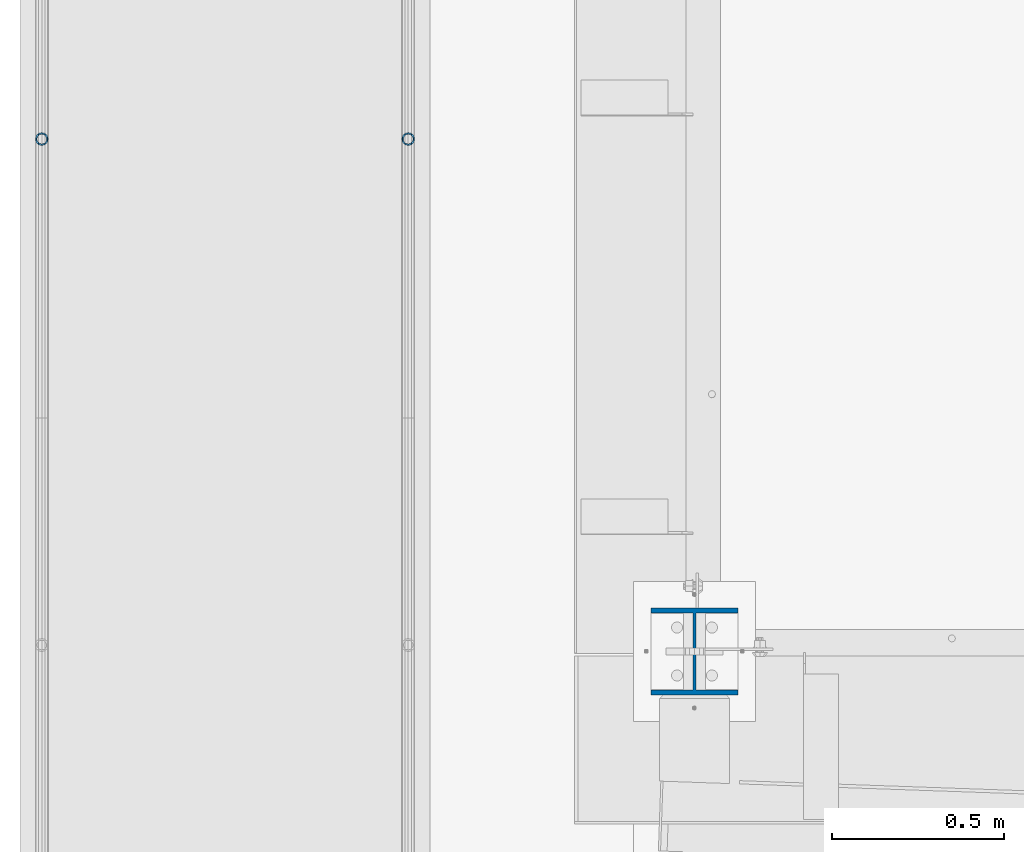
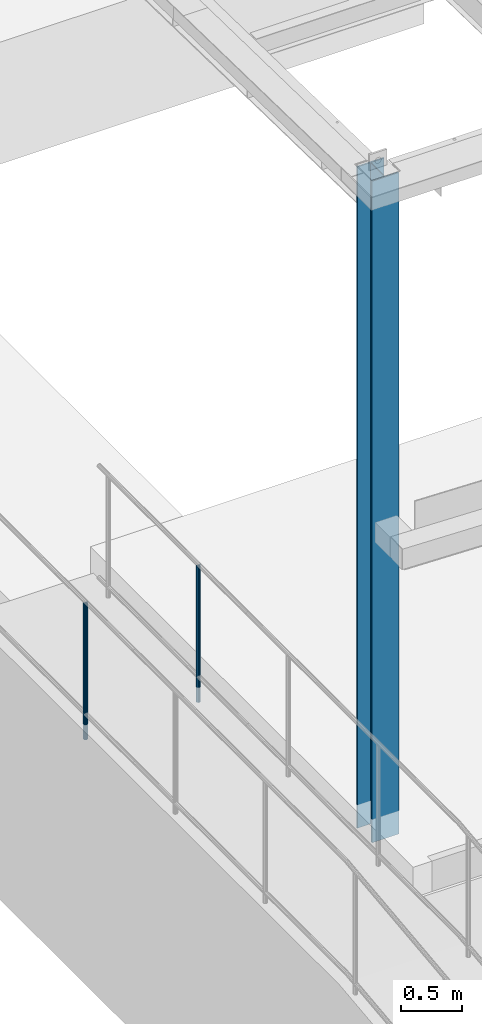
# One storey, part 885 of 1763: 3 columns, 3 elements without a shape of their own.
"""IFC2X3 building model written with IfcOpenShell, lengths in millimetres."""

import ifcopenshell
import ifcopenshell.guid

model = None  # the IFC model being written
_history = None  # IfcOwnerHistory: only IFC2X3 demands one
_inside = {}  # id of a spatial element -> (the spatial element, [elements in it])
_under = {}  # id of a project, library or spatial element -> (it, [spatial elements below it])
_declared = {}  # id of a project -> (the project, [libraries it declares])
_typed = {}  # id of a type object -> (the type object, [elements of that type])
_made_of = {}  # id of a material, layer set ... -> (it, [elements and type objects made of it])


def new_model(schema):
    """Start an empty IFC model of exactly this schema.

    Asked for "IFC4X3", IfcOpenShell would pick the latest addendum, in which some entities
    have other attributes; the version numbers below select the first issue.
    IFC2X3 requires an IfcOwnerHistory on every rooted entity: one is made here for all.
    """
    global model, _history
    if schema == "IFC4X3":
        model = ifcopenshell.file(schema_version=(4, 3, 0, 0))
    else:
        model = ifcopenshell.file(schema=schema)
    _inside.clear()
    _under.clear()
    _declared.clear()
    _typed.clear()
    _made_of.clear()
    _history = None
    if model.schema == "IFC2X3":
        org = make("IfcOrganization", Name="unknown")
        user = make(
            "IfcPersonAndOrganization",
            ThePerson=make("IfcPerson", FamilyName="unknown"),
            TheOrganization=org,
        )
        app = make(
            "IfcApplication",
            ApplicationDeveloper=org,
            Version="unknown",
            ApplicationFullName="unknown",
            ApplicationIdentifier="unknown",
        )
        _history = make(
            "IfcOwnerHistory",
            OwningUser=user,
            OwningApplication=app,
            ChangeAction="ADDED",
            CreationDate=0,
        )
    return model


def make(cls, **values):
    """One entity of the class cls with the attributes given. An attribute that is None is left unset."""
    return model.create_entity(
        cls, **{name: value for name, value in values.items() if value is not None}
    )


def rooted(cls, **values):
    """An entity with a GlobalId (a new one), such as an element, a storey or a relation."""
    return make(cls, GlobalId=ifcopenshell.guid.new(), OwnerHistory=_history, **values)


def si_unit(unit_type, name, prefix=None):
    """IfcSIUnit, for example si_unit("LENGTHUNIT", "METRE", prefix="MILLI")."""
    return make("IfcSIUnit", UnitType=unit_type, Prefix=prefix, Name=name)


def assignment(units):
    """IfcUnitAssignment: the units of a project."""
    return None if units is None else make("IfcUnitAssignment", Units=units)


def point(xyz):
    """IfcCartesianPoint."""
    return None if xyz is None else make("IfcCartesianPoint", Coordinates=xyz)


def direction(xyz):
    """IfcDirection."""
    return None if xyz is None else make("IfcDirection", DirectionRatios=xyz)


def frame(location, z_axis=None, x_axis=None):
    """IfcAxis2Placement3D, a coordinate frame: its origin and axes. An axis left out is left unset."""
    return make(
        "IfcAxis2Placement3D",
        Location=point(location),
        Axis=direction(z_axis),
        RefDirection=direction(x_axis),
    )


def origin_with_axes():
    """The frame at (0, 0, 0) with the z axis (0, 0, 1) and the x axis (1, 0, 0) written out."""
    return frame((0.0, 0.0, 0.0), z_axis=(0.0, 0.0, 1.0), x_axis=(1.0, 0.0, 0.0))


def place(relative_to, where):
    """IfcLocalPlacement: puts the frame where relative to a parent placement (None: the world)."""
    return make(
        "IfcLocalPlacement", PlacementRelTo=relative_to, RelativePlacement=where
    )


def context(
    kind, dimensions, precision=None, world=None, true_north=None, identifier=None
):
    """IfcGeometricRepresentationContext, for example the 3D "Model" context."""
    return make(
        "IfcGeometricRepresentationContext",
        ContextIdentifier=identifier,
        ContextType=kind,
        CoordinateSpaceDimension=dimensions,
        Precision=precision,
        WorldCoordinateSystem=world,
        TrueNorth=true_north,
    )


def subcontext(parent, identifier, kind, view, scale=None):
    """IfcGeometricRepresentationSubContext, for example "Body" below "Model"."""
    return make(
        "IfcGeometricRepresentationSubContext",
        ContextIdentifier=identifier,
        ContextType=kind,
        ParentContext=parent,
        TargetScale=scale,
        TargetView=view,
    )


def project(units=None, contexts=None):
    """IfcProject with its units and contexts."""
    return rooted(
        "IfcProject",
        Name="project",
        RepresentationContexts=contexts,
        UnitsInContext=assignment(units),
    )


def spatial(cls, under=None, at=None, **own):
    """A site, building, storey or space (cls), placed at a placement, below another one or the project."""
    s = rooted(cls, ObjectPlacement=at, **own)
    if under is not None:
        _under.setdefault(under.id(), (under, []))[1].append(s)
    return s


def faces_of(points, faces, orient=None, outer=None):
    """IfcFace entities. A face is a list of loops; a loop is a list of indices into points, from 0.

    orient and outer hold one flag for each loop. By default every Orientation is true, the
    first loop of a face is its IfcFaceOuterBound and the others are IfcFaceBound.
    """
    made = []
    for i, loops in enumerate(faces):
        bounds = []
        for j, loop in enumerate(loops):
            is_outer = j == 0 if outer is None else outer[i][j]
            bounds.append(
                make(
                    "IfcFaceOuterBound" if is_outer else "IfcFaceBound",
                    Bound=make("IfcPolyLoop", Polygon=[points[k] for k in loop]),
                    Orientation=True if orient is None else orient[i][j],
                )
            )
        made.append(make("IfcFace", Bounds=bounds))
    return made


def faceted_brep(points, faces, orient=None, outer=None, voids=None):
    """IfcFacetedBrep: a solid bounded by flat faces; with voids (closed shells), ...WithVoids."""
    shared = [point(p) for p in points]
    hull = make("IfcClosedShell", CfsFaces=faces_of(shared, faces, orient, outer))
    if voids is None:
        return make("IfcFacetedBrep", Outer=hull)
    return make(
        "IfcFacetedBrepWithVoids",
        Outer=hull,
        Voids=[
            make(cls, CfsFaces=faces_of(shared, fs, o, b)) for cls, fs, o, b in voids
        ],
    )


def shape(context_of_items, identifier, shape_type, items):
    """IfcShapeRepresentation: the items that make up one representation, for example the "Body"."""
    return make(
        "IfcShapeRepresentation",
        ContextOfItems=context_of_items,
        RepresentationIdentifier=identifier,
        RepresentationType=shape_type,
        Items=items,
    )


def material(Name=None, Category=None):
    """IfcMaterial."""
    return make("IfcMaterial", Name=Name, Category=Category)


def made_of(thing, what):
    """Note that an element or type object is made of a material, layer set ...; save() writes the relation."""
    if what is not None:
        _made_of.setdefault(what.id(), (what, []))[1].append(thing)
    return thing


def type_object(cls, material=None, **own):
    """A type object (cls), such as IfcWallType, which elements share."""
    return made_of(rooted(cls, **own), material)


def element(
    cls,
    number,
    at=None,
    inside=None,
    cuts=None,
    type_object=None,
    material=None,
    context=None,
    identifier="Body",
    shape_type=None,
    held_by="IfcProductDefinitionShape",
    body=None,
    shapes=None,
    **own,
):
    """One element of the class cls, such as IfcWall. Its Tag is "e" and its number.

    at: its placement. inside: the storey or other place that contains it. cuts: it is an
    opening in that element (IfcRelVoidsElement). A single representation is given by context,
    identifier, shape_type and body (its items); several are given by shapes. held_by: the class
    of the entity that holds the representations. save() writes the other relations.
    """
    e = rooted(cls, Tag="e%d" % number, ObjectPlacement=at, **own)
    if body is not None:
        shapes = [shape(context, identifier, shape_type, body)]
    if shapes is not None:
        e.Representation = make(held_by, Representations=shapes)
    if inside is not None:
        _inside.setdefault(inside.id(), (inside, []))[1].append(e)
    if cuts is not None:
        rooted(
            "IfcRelVoidsElement", RelatingBuildingElement=cuts, RelatedOpeningElement=e
        )
    if type_object is not None:
        _typed.setdefault(type_object.id(), (type_object, []))[1].append(e)
    return made_of(e, material)


def aggregate(whole, parts):
    """IfcRelAggregates: a whole, such as a stair, and the parts it consists of."""
    return rooted("IfcRelAggregates", RelatingObject=whole, RelatedObjects=parts)


def save(model, path):
    """Write the relations noted so far, then the file.

    IfcRelAggregates (storeys below a building ...), IfcRelContainedInSpatialStructure (elements
    in a storey), IfcRelDefinesByType, IfcRelAssociatesMaterial and IfcRelDeclares: one each for
    every whole, place, type object, material and project.
    """
    for whole, parts in _under.values():
        aggregate(whole, parts)
    for where, things in _inside.values():
        rooted(
            "IfcRelContainedInSpatialStructure",
            RelatedElements=things,
            RelatingStructure=where,
        )
    for kind, things in _typed.values():
        rooted("IfcRelDefinesByType", RelatedObjects=things, RelatingType=kind)
    for what, things in _made_of.values():
        rooted("IfcRelAssociatesMaterial", RelatedObjects=things, RelatingMaterial=what)
    for by, libraries in _declared.values():
        rooted("IfcRelDeclares", RelatingContext=by, RelatedDefinitions=libraries)
    model.write(path)


model = new_model("IFC2X3")

# Units and contexts
model_context = context("Model", 3, precision=1e-05, world=origin_with_axes())
body_context = subcontext(model_context, "Body", "Model", "MODEL_VIEW")
ifc_project = project(units=[si_unit("LENGTHUNIT", "METRE", prefix="MILLI"), si_unit("AREAUNIT", "SQUARE_METRE"), si_unit("VOLUMEUNIT", "CUBIC_METRE"), si_unit("MASSUNIT", "GRAM", prefix="KILO"), si_unit("TIMEUNIT", "SECOND"), si_unit("PLANEANGLEUNIT", "RADIAN"), si_unit("SOLIDANGLEUNIT", "STERADIAN"), si_unit("THERMODYNAMICTEMPERATUREUNIT", "DEGREE_CELSIUS"), si_unit("LUMINOUSINTENSITYUNIT", "LUMEN")], contexts=[model_context])

# Site, building, storey
site_placement = place(None, origin_with_axes())
site = spatial("IfcSite", under=ifc_project, at=site_placement, CompositionType="ELEMENT")
building_placement = place(site_placement, origin_with_axes())
building = spatial("IfcBuilding", under=site, at=building_placement, Name="Undefined", CompositionType="ELEMENT")
storey_placement = place(building_placement, origin_with_axes())
storey = spatial("IfcBuildingStorey", under=building, at=storey_placement, Name="Undefined", CompositionType="ELEMENT", Elevation=0.0)

# Assembly, column
assembly_1_placement = place(storey_placement, origin_with_axes())
assembly_1 = element("IfcElementAssembly", 1, at=assembly_1_placement, inside=storey, Name="GUARDRAIL", AssemblyPlace="NOTDEFINED", PredefinedType="RIGID_FRAME")
ifc_material_1 = material(Name="STEEL/A513")
column_type_1 = type_object("IfcColumnType", PredefinedType="NOTDEFINED")
column_1_placement = place(assembly_1_placement, frame((-97200.6527017878, 10788.4431732146, 5777.83146284698), z_axis=(0.0, -1.0, 0.0), x_axis=(0.0, 0.0, 1.0)))
column_1 = element("IfcColumn", 2, at=column_1_placement, type_object=column_type_1, material=ifc_material_1, Name="POST TUBE", context=body_context, shape_type="Brep", body=[
    faceted_brep([(1355.1020678918, -9.52499999999418, 16.4977839408602), (1355.10207152849, -9.52499999999418, 9.99208795533559), (1354.46401618279, -7.14375000000291, 12.3733379553378), (1352.54985306944, 0.0, 14.2874999987689), (1352.5498504072, 0.0, 19.0499999987696), (1354.46401618279, 7.14375000000291, 12.3733379553378), (1355.10207152849, 9.52499999999418, 9.99208795533559), (1355.1020678918, 9.52499999999418, 16.4977839408602), (1371.59986105617, 19.0500000000029, -1.24782673083246e-09), (1362.07485573169, 16.4977839420899, 9.5249999987609), (1362.07486638065, 16.4977839420899, -9.52500000124019), (1357.95041107718, 12.3733379565674, 7.143749998766), (1359.86457711397, 14.2875000000058, -1.23691279441118e-09), (1357.95041906389, 12.3733379565674, -7.14375000123619), (1355.10208269966, 9.52499999999418, -9.99208795780396), (1355.10208633635, 9.52499999999418, -16.4977839433304), (1354.46403001618, 7.14375000000291, -12.3733379578043), (1352.54986904289, 0.0, -14.2875000012336), (1352.54987170513, 0.0, -19.0500000012325), (1355.10208269966, -9.52499999999418, -9.99208795780396), (1355.10208633635, -9.52499999999418, -16.4977839433304), (1354.46403001618, -7.14375000000291, -12.3733379578043), (1371.59986105617, -19.0500000000029, -1.24782673083246e-09), (1362.07486638065, -16.4977839420899, -9.52500000124019), (1362.07485573169, -16.4977839420899, 9.5249999987609), (1357.95041906389, -12.3733379565674, -7.14375000123619), (1359.86457711397, -14.2875000000058, -1.23691279441118e-09), (1357.95041107718, -12.3733379565674, 7.143749998766), (0.0, -16.4977839420899, -9.52500000000146), (0.0, -9.52499999999418, -16.4977839420935), (1.45519152283669e-11, 1.81898940354586e-12, -19.0499999999993), (0.0, 9.52499999999418, -16.4977839420935), (0.0, 16.4977839420899, -9.52500000000146), (0.0, 19.0500000000029, 0.0), (0.0, 16.4977839420899, 9.52500000000146), (0.0, 9.52499999999418, 16.4977839420935), (1.45519152283669e-11, 1.81898940354586e-12, 19.0499999999993), (0.0, -9.52499999999418, 16.4977839420935), (0.0, -16.4977839420899, 9.52500000000146), (0.0, -19.0500000000029, 0.0), (0.0, -12.3733379565674, -7.14374999999927), (0.0, -7.14375000000291, -12.373337956571), (0.0, 0.0, -14.2874999999985), (0.0, 7.14375000000291, -12.373337956571), (0.0, 12.3733379565674, -7.14374999999927), (0.0, 14.2875000000058, 0.0), (0.0, 12.3733379565674, 7.14374999999927), (0.0, 7.14375000000291, 12.373337956571), (0.0, 0.0, 14.2874999999985), (0.0, -7.14375000000291, 12.373337956571), (0.0, -12.3733379565674, 7.14374999999927), (0.0, -14.2875000000058, 0.0)], [[[0, 1, 2, 3, 4]], [[4, 3, 5, 6, 7]], [[8, 9, 10]], [[7, 6, 11, 12, 13, 14, 15, 10, 9]], [[16, 17, 18, 15, 14]], [[19, 20, 18, 17, 21]], [[22, 23, 24]], [[24, 23, 20, 19, 25, 26, 27, 1, 0]], [[28, 29, 20, 23]], [[29, 30, 18, 20]], [[30, 31, 15, 18]], [[31, 32, 10, 15]], [[32, 33, 8, 10]], [[33, 34, 9, 8]], [[34, 35, 7, 9]], [[35, 36, 4, 7]], [[36, 37, 0, 4]], [[37, 38, 24, 0]], [[38, 39, 22, 24]], [[39, 28, 23, 22]], [[38, 37, 36, 35, 34, 33, 32, 31, 30, 29, 28, 39], [40, 41, 42, 43, 44, 45, 46, 47, 48, 49, 50, 51]], [[40, 51, 26, 25]], [[21, 41, 40, 25, 19]], [[42, 41, 21, 17]], [[43, 42, 17, 16]], [[44, 43, 16, 14, 13]], [[45, 44, 13, 12]], [[46, 45, 12, 11]], [[5, 47, 46, 11, 6]], [[48, 47, 5, 3]], [[49, 48, 3, 2]], [[50, 49, 2, 1, 27]], [[51, 50, 27, 26]]]),
])
aggregate(assembly_1, [column_1])

assembly_2_placement = place(storey_placement, origin_with_axes())
assembly_2 = element("IfcElementAssembly", 3, at=assembly_2_placement, inside=storey, Name="GUARDRAIL", AssemblyPlace="NOTDEFINED", PredefinedType="RIGID_FRAME")
column_2_placement = place(assembly_2_placement, frame((-96133.8527017878, 10788.4431732146, 5777.83146284698), z_axis=(0.0, -1.0, 0.0), x_axis=(0.0, 0.0, 1.0)))
column_2 = element("IfcColumn", 4, at=column_2_placement, type_object=column_type_1, material=ifc_material_1, Name="POST TUBE", context=body_context, shape_type="Brep", body=[
    faceted_brep([(1355.1020678918, -9.52499999999418, 16.4977839408602), (1355.10207152849, -9.52499999999418, 9.99208795533559), (1354.46401618279, -7.14375000000291, 12.3733379553378), (1352.54985306944, 0.0, 14.2874999987689), (1352.5498504072, 0.0, 19.0499999987696), (1354.46401618279, 7.14375000000291, 12.3733379553378), (1355.10207152849, 9.52499999999418, 9.99208795533559), (1355.1020678918, 9.52499999999418, 16.4977839408602), (1371.59986105617, 19.0500000000029, -1.24782673083246e-09), (1362.07485573169, 16.4977839420899, 9.5249999987609), (1362.07486638065, 16.4977839420899, -9.52500000124019), (1357.95041107718, 12.3733379565674, 7.143749998766), (1359.86457711397, 14.2875000000058, -1.23691279441118e-09), (1357.95041906389, 12.3733379565674, -7.14375000123619), (1355.10208269966, 9.52499999999418, -9.99208795780396), (1355.10208633635, 9.52499999999418, -16.4977839433304), (1354.46403001618, 7.14375000000291, -12.3733379578043), (1352.54986904289, 0.0, -14.2875000012336), (1352.54987170513, 0.0, -19.0500000012325), (1355.10208269966, -9.52499999999418, -9.99208795780396), (1355.10208633635, -9.52499999999418, -16.4977839433304), (1354.46403001618, -7.14375000000291, -12.3733379578043), (1371.59986105617, -19.0500000000029, -1.24782673083246e-09), (1362.07486638065, -16.4977839420899, -9.52500000124019), (1362.07485573169, -16.4977839420899, 9.5249999987609), (1357.95041906389, -12.3733379565674, -7.14375000123619), (1359.86457711397, -14.2875000000058, -1.23691279441118e-09), (1357.95041107718, -12.3733379565674, 7.143749998766), (0.0, -16.4977839420899, -9.52500000000146), (0.0, -9.52499999999418, -16.4977839420935), (1.45519152283669e-11, 1.81898940354586e-12, -19.0499999999993), (0.0, 9.52499999999418, -16.4977839420935), (0.0, 16.4977839420899, -9.52500000000146), (0.0, 19.0500000000029, 0.0), (0.0, 16.4977839420899, 9.52500000000146), (0.0, 9.52499999999418, 16.4977839420935), (1.45519152283669e-11, 1.81898940354586e-12, 19.0499999999993), (0.0, -9.52499999999418, 16.4977839420935), (0.0, -16.4977839420899, 9.52500000000146), (0.0, -19.0500000000029, 0.0), (0.0, -12.3733379565674, -7.14374999999927), (0.0, -7.14375000000291, -12.373337956571), (0.0, 0.0, -14.2874999999985), (0.0, 7.14375000000291, -12.373337956571), (0.0, 12.3733379565674, -7.14374999999927), (0.0, 14.2875000000058, 0.0), (0.0, 12.3733379565674, 7.14374999999927), (0.0, 7.14375000000291, 12.373337956571), (0.0, 0.0, 14.2874999999985), (0.0, -7.14375000000291, 12.373337956571), (0.0, -12.3733379565674, 7.14374999999927), (0.0, -14.2875000000058, 0.0)], [[[0, 1, 2, 3, 4]], [[4, 3, 5, 6, 7]], [[8, 9, 10]], [[7, 6, 11, 12, 13, 14, 15, 10, 9]], [[16, 17, 18, 15, 14]], [[19, 20, 18, 17, 21]], [[22, 23, 24]], [[24, 23, 20, 19, 25, 26, 27, 1, 0]], [[28, 29, 20, 23]], [[29, 30, 18, 20]], [[30, 31, 15, 18]], [[31, 32, 10, 15]], [[32, 33, 8, 10]], [[33, 34, 9, 8]], [[34, 35, 7, 9]], [[35, 36, 4, 7]], [[36, 37, 0, 4]], [[37, 38, 24, 0]], [[38, 39, 22, 24]], [[39, 28, 23, 22]], [[38, 37, 36, 35, 34, 33, 32, 31, 30, 29, 28, 39], [40, 41, 42, 43, 44, 45, 46, 47, 48, 49, 50, 51]], [[40, 51, 26, 25]], [[21, 41, 40, 25, 19]], [[42, 41, 21, 17]], [[43, 42, 17, 16]], [[44, 43, 16, 14, 13]], [[45, 44, 13, 12]], [[46, 45, 12, 11]], [[5, 47, 46, 11, 6]], [[48, 47, 5, 3]], [[49, 48, 3, 2]], [[50, 49, 2, 1, 27]], [[51, 50, 27, 26]]]),
])
aggregate(assembly_2, [column_2])

assembly_3_placement = place(storey_placement, origin_with_axes())
assembly_3 = element("IfcElementAssembly", 5, at=assembly_3_placement, inside=storey, Name="COLUMN", AssemblyPlace="NOTDEFINED", PredefinedType="RIGID_FRAME")
ifc_material_2 = material(Name="STEEL/A992")
column_type_2 = type_object("IfcColumnType", Name="W10X49", PredefinedType="NOTDEFINED")
column_3_placement = place(assembly_3_placement, frame((-95300.2372736984, 9296.40000000001, 5029.2), z_axis=(0.0, 1.0, 0.0), x_axis=(0.0, 0.0, 1.0)))
column_3 = element("IfcColumn", 6, at=column_3_placement, type_object=column_type_2, material=ifc_material_2, Name="COLUMN", ObjectType="W10X49", context=body_context, shape_type="Brep", body=[
    faceted_brep([(69.8500000000085, 127.0, -127.0), (69.8500000000085, 127.0, -112.712500000001), (6680.11703650971, 127.0, -112.7125), (6680.11703650971, 127.0, -127.0), (69.8500000000085, 3.96875, -112.712500000001), (6680.11703650971, 3.96875, -112.7125), (69.8500000000085, 3.96875, 112.712500000001), (6680.11703650971, 3.96875, 112.7125), (69.8500000000085, 127.0, 112.712500000001), (6680.11703650971, 127.0, 112.7125), (69.8500000000085, 127.0, 127.0), (6680.11703650971, 127.0, 127.0), (69.8500000000085, -127.0, 127.0), (6680.11703650971, -127.0, 127.0), (69.8500000000085, -127.0, 112.712500000001), (6680.11703650971, -127.0, 112.7125), (69.8500000000085, -3.96875, 112.712500000001), (6680.11703650971, -3.96875, 112.7125), (69.8500000000085, -3.96875, -112.712500000001), (6680.11703650971, -3.96875, -112.7125), (69.8500000000085, -127.0, -112.712500000001), (6680.11703650971, -127.0, -112.7125), (69.8500000000085, -127.0, -127.0), (6680.11703650971, -127.0, -127.0)], [[[0, 1, 2, 3]], [[1, 4, 5, 2]], [[4, 6, 7, 5]], [[6, 8, 9, 7]], [[8, 10, 11, 9]], [[10, 12, 13, 11]], [[12, 14, 15, 13]], [[14, 16, 17, 15]], [[16, 18, 19, 17]], [[18, 20, 21, 19]], [[20, 22, 23, 21]], [[22, 0, 3, 23]], [[5, 7, 9, 11, 13, 15, 17, 19, 21, 23, 3, 2]], [[22, 20, 18, 16, 14, 12, 10, 8, 6, 4, 1, 0]]]),
])
aggregate(assembly_3, [column_3])

save(model, "model.ifc")
